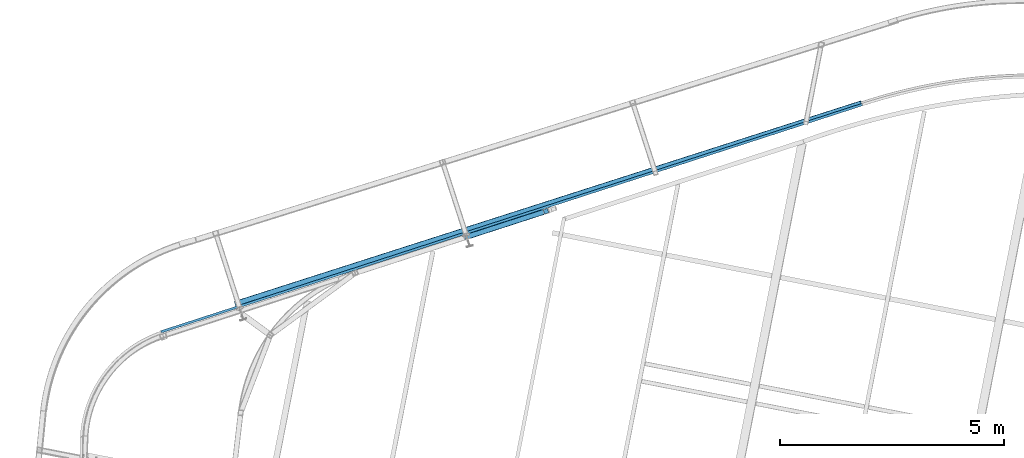
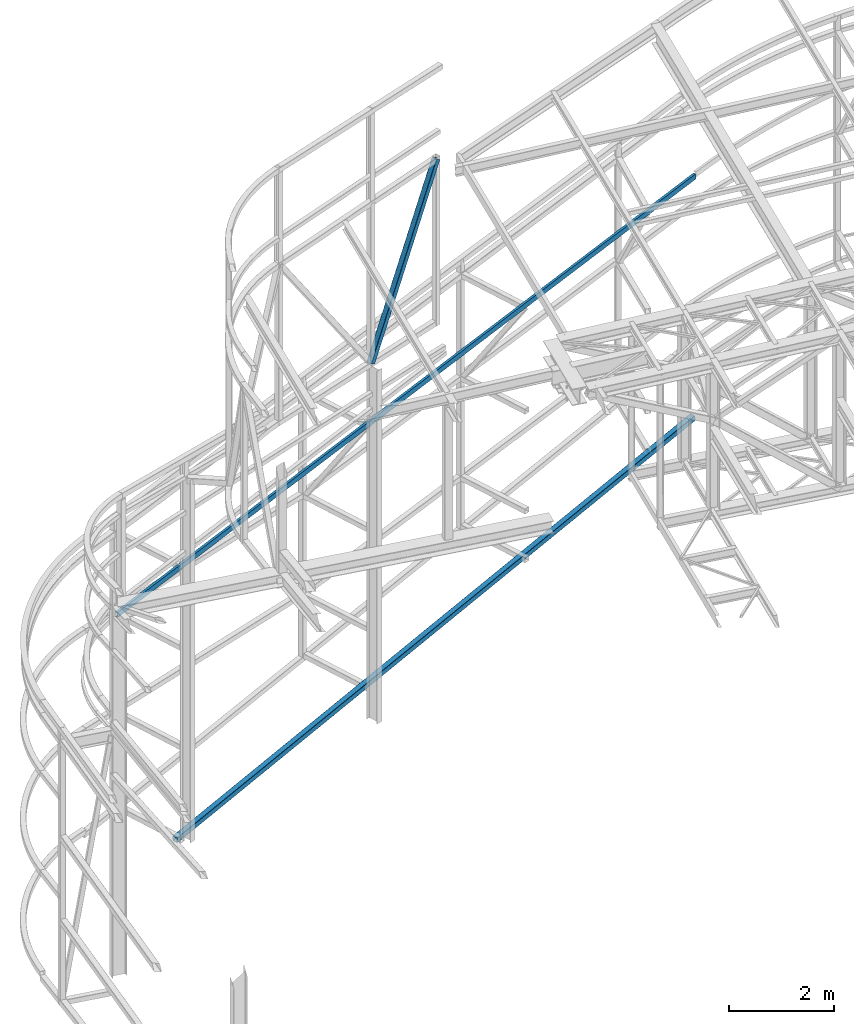
# One storey, part 83 of 215: 2 beams, 1 member, 3 elements without a shape of their own.
"""IFC2X3 building model written with IfcOpenShell, lengths in millimetres."""

from ifc_helpers import new_model, si_unit, frame, origin_with_axes, origin_2d_with_axis, place, context, subcontext, project, spatial, hollow_rectangle, u_section, extrude, material, type_object, element, aggregate, save


model = new_model("IFC2X3")

# Units and contexts
model_context = context("Model", 3, precision=1e-05, world=origin_with_axes())
body_context = subcontext(model_context, "Body", "Model", "MODEL_VIEW")
ifc_project = project(units=[si_unit("LENGTHUNIT", "METRE", prefix="MILLI"), si_unit("AREAUNIT", "SQUARE_METRE"), si_unit("VOLUMEUNIT", "CUBIC_METRE"), si_unit("MASSUNIT", "GRAM", prefix="KILO"), si_unit("TIMEUNIT", "SECOND"), si_unit("PLANEANGLEUNIT", "RADIAN"), si_unit("SOLIDANGLEUNIT", "STERADIAN"), si_unit("THERMODYNAMICTEMPERATUREUNIT", "DEGREE_CELSIUS"), si_unit("LUMINOUSINTENSITYUNIT", "LUMEN")], contexts=[model_context])

# Site, building, storey
site_placement = place(None, origin_with_axes())
site = spatial("IfcSite", under=ifc_project, at=site_placement, CompositionType="ELEMENT")
building_placement = place(site_placement, origin_with_axes())
building = spatial("IfcBuilding", under=site, at=building_placement, Name="Undefined", CompositionType="ELEMENT")
storey_placement = place(building_placement, origin_with_axes())
storey = spatial("IfcBuildingStorey", under=building, at=storey_placement, Name="Undefined", CompositionType="ELEMENT", Elevation=0.0)

# Assembly, beam
assembly_1_placement = place(storey_placement, origin_with_axes())
assembly_1 = element("IfcElementAssembly", 1, at=assembly_1_placement, inside=storey, Name="Steel Assembly", AssemblyPlace="NOTDEFINED", PredefinedType="RIGID_FRAME")
ifc_material = material(Name="STEEL/S275JR")
beam_type_1 = type_object("IfcBeamType", PredefinedType="NOTDEFINED")
beam_1_placement = place(assembly_1_placement, frame((42403.8334060114, 57839.1600811477, -103.909710779869), z_axis=(-0.304740811911624, 0.952434117723799, -0.00151292799956127), x_axis=(0.941679591742773, 0.301537084917633, 0.149381835959195)))
beam_1 = element("IfcBeam", 2, at=beam_1_placement, type_object=beam_type_1, material=ifc_material, Name="LISSE", context=body_context, shape_type="SweptSolid", body=[
    extrude(hollow_rectangle(XDim=120.0, YDim=120.0, WallThickness=5.0, InnerFilletRadius=5.0, OuterFilletRadius=10.0, at=origin_2d_with_axis()), frame((14858.6010221538, 1.81898940354586e-12, -1.14701259859199e-12), z_axis=(-1.0, 0.0, 0.0), x_axis=(-6.93889390390723e-18, -1.0, -3.46944695195361e-18)), (0.0, 0.0, 1.0), 14858.6),
])
aggregate(assembly_1, [beam_1])

# Assembly, member
assembly_2_placement = place(storey_placement, origin_with_axes())
assembly_2 = element("IfcElementAssembly", 3, at=assembly_2_placement, inside=storey, Name="Steel Assembly", AssemblyPlace="NOTDEFINED", PredefinedType="RIGID_FRAME")
member_type = type_object("IfcMemberType", PredefinedType="NOTDEFINED")
member_placement = place(assembly_2_placement, frame((49346.4517895089, 59907.3755930807, 12064.9313899518), z_axis=(0.85412888234212, 0.276787229110869, -0.440287045176357), x_axis=(-0.418843816027579, -0.135729656008937, -0.897857070059122)))
member = element("IfcMember", 4, at=member_placement, type_object=member_type, material=ifc_material, context=body_context, shape_type="SweptSolid", body=[
    extrude(hollow_rectangle(XDim=120.0, YDim=120.0, WallThickness=5.0, InnerFilletRadius=5.0, OuterFilletRadius=10.0, at=origin_2d_with_axis()), frame((4225.39832347066, -7.3167387672496e-12, -7.04140088883694e-12), z_axis=(-1.0, 0.0, 0.0), x_axis=(-6.93889390390723e-18, -1.0, -3.46944695195361e-18)), (0.0, 0.0, 1.0), 4225.4),
])
aggregate(assembly_2, [member])

# Assembly, beam
assembly_3_placement = place(storey_placement, origin_with_axes())
assembly_3 = element("IfcElementAssembly", 5, at=assembly_3_placement, inside=storey, Name="Steel Assembly", AssemblyPlace="NOTDEFINED", PredefinedType="RIGID_FRAME")
beam_type_2 = type_object("IfcBeamType", Name="UPN120", PredefinedType="NOTDEFINED")
beam_2_placement = place(assembly_3_placement, frame((40751.0941071243, 57213.9608708522, 6083.90130625765), z_axis=(0.0954481209807289, 0.029183893994109, -0.995006510799095), x_axis=(0.946550067025082, 0.306730597008128, 0.0997963500026445)))
beam_2 = element("IfcBeam", 6, at=beam_2_placement, type_object=beam_type_2, material=ifc_material, ObjectType="UPN120", context=body_context, shape_type="SweptSolid", body=[
    extrude(u_section(Depth=120.0, FlangeWidth=55.0, WebThickness=7.0, FlangeThickness=9.0, FilletRadius=9.0, EdgeRadius=4.5, FlangeSlope=0.0798299857122373, at=origin_2d_with_axis()), frame((16556.4320501307, -1.21480141375136e-12, -2.29766650846213e-13), z_axis=(-1.0, 0.0, 0.0), x_axis=(-6.93889390390723e-18, -1.0, -3.46944695195361e-18)), (0.0, 0.0, 1.0), 16556.4),
])
aggregate(assembly_3, [beam_2])

save(model, "model.ifc")
